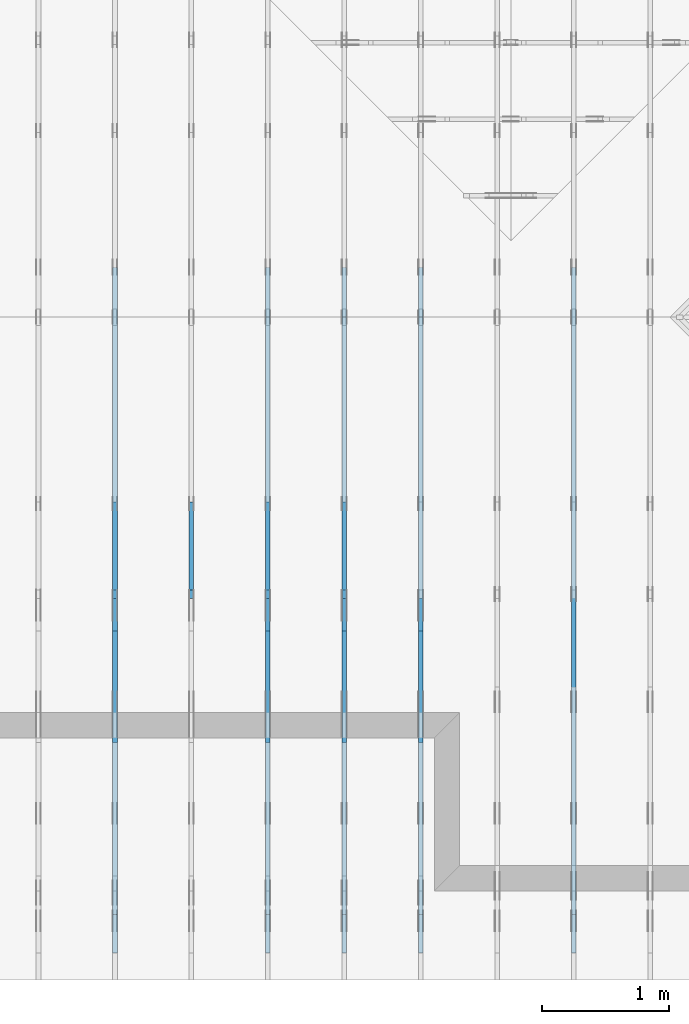
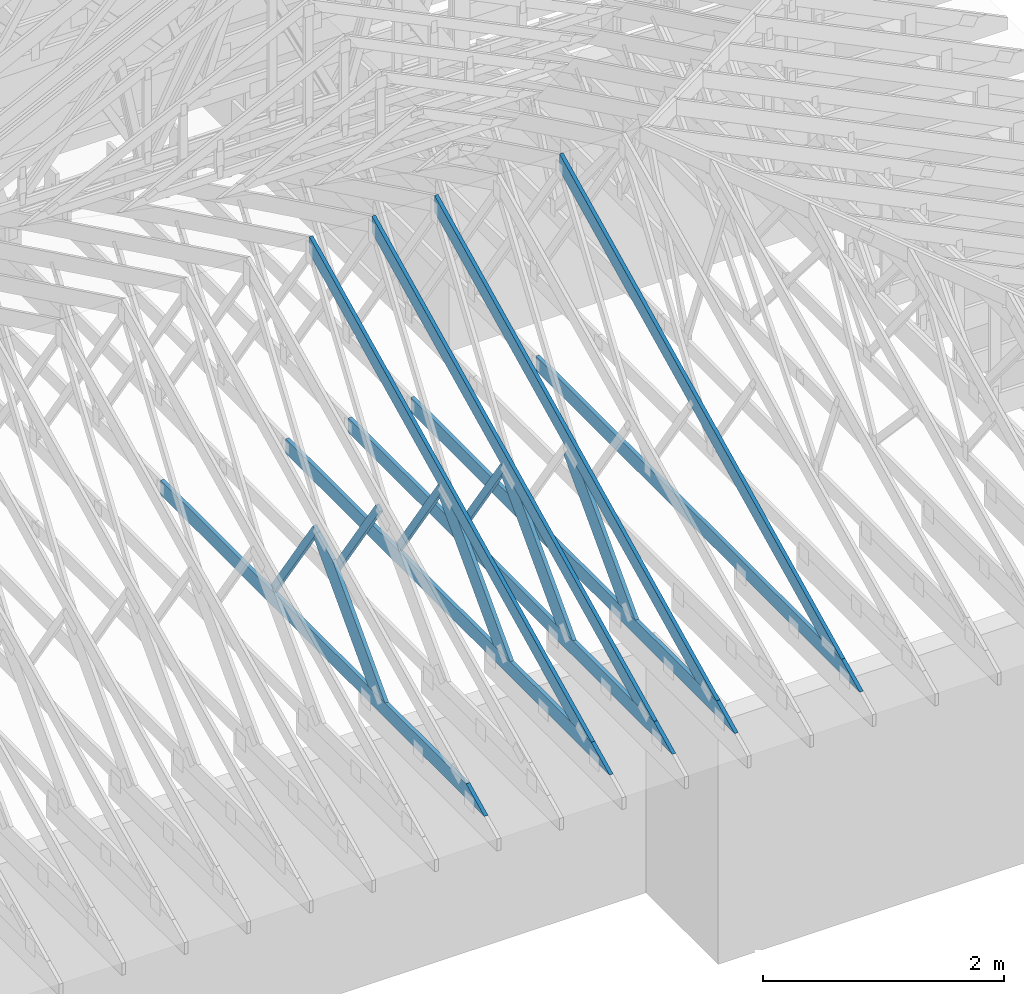
# One storey, part 14 of 159: 17 members, 6 elements without a shape of their own.
"""IFC2X3 building model written with IfcOpenShell, lengths in millimetres."""

from ifc_helpers import new_model, si_unit, frame, origin, origin_with_axes, origin_2d, place, context, project, spatial, faceted_brep, element, aggregate, save


model = new_model("IFC2X3")

# Units and contexts
model_context = context("Model", 3, precision=1e-05, world=origin())
plan_context = context("Plan", 2, precision=1e-05, world=origin_2d())
ifc_project = project(units=[si_unit("LENGTHUNIT", "METRE", prefix="MILLI"), si_unit("AREAUNIT", "SQUARE_METRE"), si_unit("VOLUMEUNIT", "CUBIC_METRE"), si_unit("SOLIDANGLEUNIT", "STERADIAN"), si_unit("PLANEANGLEUNIT", "RADIAN"), si_unit("MASSUNIT", "GRAM"), si_unit("TIMEUNIT", "SECOND"), si_unit("THERMODYNAMICTEMPERATUREUNIT", "DEGREE_CELSIUS"), si_unit("LUMINOUSINTENSITYUNIT", "LUMEN")], contexts=[model_context, plan_context])

# Site, building, storey
site_placement = place(None, origin_with_axes())
site = spatial("IfcSite", under=ifc_project, at=site_placement, CompositionType="ELEMENT")
building_placement = place(site_placement, origin_with_axes())
building = spatial("IfcBuilding", under=site, at=building_placement, Name="Plan 1", CompositionType="ELEMENT")
storey_placement = place(building_placement, origin_with_axes())
storey = spatial("IfcBuildingStorey", under=building, at=storey_placement, Name="Etasje 1", CompositionType="ELEMENT", Elevation=0.0)

# Assembly, members
assembly_1_placement = place(storey_placement, frame((15075.02226140475, -699.9989301294845, 1.1021457184401395e-15), z_axis=(-1.0, 1.836909530733566e-16, 6.123031769111886e-17), x_axis=(-1.836909530733566e-16, -1.0, 0.0)))
assembly_1 = element("IfcElementAssembly", 1, at=assembly_1_placement, inside=storey, Name="T7 (103)", AssemblyPlace="FACTORY", PredefinedType="TRUSS")
member_1_placement = place(assembly_1_placement, frame((-5264.878447895178, 2523.1876964355156, -36.0), z_axis=(0.0, 0.0, 1.0), x_axis=(0.8987940462991668, -0.4383711467890778, 0.0)))
member_1 = element("IfcMember", 2, at=member_1_placement, Name="T7-O3", context=model_context, shape_type="Brep", body=[
    faceted_brep([(5212.95535395332, 148.00000154094027, 36.0), (0.0, 148.00000154094027, 36.0), (72.18440200989608, 5.7974317996922764e-05, 36.0), (4909.510382240189, 5.7974317996922764e-05, 36.0), (0.0, 148.00000154094027, 0.0), (5212.95535395332, 148.00000154094027, 6.383818248643616e-13), (4909.510382240189, 5.7974317996922764e-05, 6.012217608248263e-13), (72.18440200989608, 5.7974317996922764e-05, 8.839747734818752e-15), (72.18447769922204, 9.2140264804641e-06, -7.888609052210118e-31), (72.18447769922206, 9.2140264804641e-06, 36.0), (5.4591825588090614e-05, 148.00000921330525, 36.0), (5.4591825588090614e-05, 148.00000921330525, -7.888609052210118e-31), (4909.510401129447, 9.21290418597988e-06, 1.6550270895783706e-28), (4909.510401129447, 9.212904188184172e-06, 36.0), (72.18447769922204, 9.21402643937418e-06, 36.0), (72.18447769922204, 9.214026437169889e-06, 2.433384460947949e-30), (5212.955369681814, 148.00000921223887, 1.0605704288840677e-29), (5212.955369681814, 148.00000921223887, 36.0), (4909.510401129447, 9.212906661559828e-06, 36.0), (4909.510401129447, 9.212906661559828e-06, -1.359749288005947e-29), (5.459182557387976e-05, 148.00000921330525, 0.0), (5.459182557387976e-05, 148.00000921330525, 36.0), (5212.955369681813, 148.00000921223887, 36.0), (5212.955369681813, 148.00000921223887, 7.888609052210118e-30)], [[[0, 1, 2, 3]], [[4, 5, 6, 7]], [[8, 9, 10, 11]], [[12, 13, 14, 15]], [[16, 17, 18, 19]], [[20, 21, 22, 23]]]),
])
member_2_placement = place(assembly_1_placement, frame((-211.18128967285153, 370.99999999999994, -36.0), z_axis=(0.0, 0.0, 1.0), x_axis=(-1.0, 1.2246063538223773e-16, 0.0)))
member_2 = element("IfcMember", 3, at=member_2_placement, Name="T7-U32", context=model_context, shape_type="Brep", body=[
    faceted_brep([(5379.999862670898, 148.00000000000063, 36.0), (0.0, 148.00000000000063, 36.0), (303.4449920654297, 0.0, 36.0), (5379.999862670898, 0.0, 36.0), (0.0, 148.00000000000063, 0.0), (5379.999862670898, 148.00000000000063, 6.588382015390299e-13), (5379.999862670898, 0.0, 6.588382015390299e-13), (303.4449920654297, 0.0, 3.7160066531890605e-14), (303.44497456401575, -1.8474111129762605e-13, 1.4199496293978212e-29), (303.44497456401575, -1.8474111129762605e-13, 36.0), (6.010755903673726e-06, 148.0, 36.0), (6.010755903673726e-06, 148.0, -1.5777218104420236e-30), (5380.000006010756, -1.0494167752128893e-12, 1.2690585325561372e-28), (5380.000006010756, -1.047212483776009e-12, 36.0), (303.44497456401587, -1.146952517202135e-13, 36.0), (303.44497456401587, -1.1689954315709379e-13, 7.157796165455513e-30), (5380.000006010756, 148.000000000001, 0.0), (5380.000006010756, 148.000000000001, 36.0), (5380.000006010756, 1.0231815394945443e-12, 36.0), (5380.000006010756, 1.0231815394945443e-12, 0.0), (6.010755896568298e-06, 147.99999999999997, 0.0), (6.010755896568298e-06, 147.99999999999997, 36.0), (5380.000006010756, 148.00000000000082, 36.0), (5380.000006010756, 148.00000000000082, -9.466330862652142e-30)], [[[0, 1, 2, 3]], [[4, 5, 6, 7]], [[8, 9, 10, 11]], [[12, 13, 14, 15]], [[16, 17, 18, 19]], [[20, 21, 22, 23]]]),
])
aggregate(assembly_1, [member_1, member_2])

assembly_2_placement = place(storey_placement, frame((13875.022261404752, -699.9989301294836, 1.1021457184401395e-15), z_axis=(-1.0, 1.836909530733566e-16, 6.123031769111886e-17), x_axis=(-1.836909530733566e-16, -1.0, 0.0)))
assembly_2 = element("IfcElementAssembly", 4, at=assembly_2_placement, inside=storey, Name="T6 (101)", AssemblyPlace="FACTORY", PredefinedType="TRUSS")
member_3_placement = place(assembly_2_placement, frame((-5264.878447895178, 2523.1876964355156, -36.0), z_axis=(0.0, 0.0, 1.0), x_axis=(0.8987940462991668, -0.4383711467890778, 0.0)))
member_3 = element("IfcMember", 5, at=member_3_placement, Name="T6-O3", context=model_context, shape_type="Brep", body=[
    faceted_brep([(5212.95535395332, 148.00000154094027, 36.0), (0.0, 148.00000154094027, 36.0), (72.18440200989608, 5.7974317996922764e-05, 36.0), (4909.510382240189, 5.7974317996922764e-05, 36.0), (0.0, 148.00000154094027, 0.0), (5212.95535395332, 148.00000154094027, 6.383818248643616e-13), (4909.510382240189, 5.7974317996922764e-05, 6.012217608248263e-13), (72.18440200989608, 5.7974317996922764e-05, 8.839747734818752e-15), (72.18447769922204, 9.2140264804641e-06, -7.888609052210118e-31), (72.18447769922206, 9.2140264804641e-06, 36.0), (5.4591825588090614e-05, 148.00000921330525, 36.0), (5.4591825588090614e-05, 148.00000921330525, -7.888609052210118e-31), (4909.510401129447, 9.21290418597988e-06, 1.6550270895783706e-28), (4909.510401129447, 9.212904188184172e-06, 36.0), (72.18447769922204, 9.21402643937418e-06, 36.0), (72.18447769922204, 9.214026437169889e-06, 2.433384460947949e-30), (5212.955369681814, 148.00000921223887, 1.0605704288840677e-29), (5212.955369681814, 148.00000921223887, 36.0), (4909.510401129447, 9.212906661559828e-06, 36.0), (4909.510401129447, 9.212906661559828e-06, -1.359749288005947e-29), (5.459182557387976e-05, 148.00000921330525, 0.0), (5.459182557387976e-05, 148.00000921330525, 36.0), (5212.955369681813, 148.00000921223887, 36.0), (5212.955369681813, 148.00000921223887, 7.888609052210118e-30)], [[[0, 1, 2, 3]], [[4, 5, 6, 7]], [[8, 9, 10, 11]], [[12, 13, 14, 15]], [[16, 17, 18, 19]], [[20, 21, 22, 23]]]),
])
member_4_placement = place(assembly_2_placement, frame((-211.18128967285153, 370.99999999999994, -36.0), z_axis=(0.0, 0.0, 1.0), x_axis=(-1.0, 1.2246063538223773e-16, 0.0)))
member_4 = element("IfcMember", 6, at=member_4_placement, Name="T6-U32", context=model_context, shape_type="Brep", body=[
    faceted_brep([(5379.999862670898, 148.00000000000063, 36.0), (0.0, 148.00000000000063, 36.0), (303.4449920654297, 0.0, 36.0), (5379.999862670898, 0.0, 36.0), (0.0, 148.00000000000063, 0.0), (5379.999862670898, 148.00000000000063, 6.588382015390299e-13), (5379.999862670898, 0.0, 6.588382015390299e-13), (303.4449920654297, 0.0, 3.7160066531890605e-14), (303.44497456401575, -1.8474111129762605e-13, 1.4199496293978212e-29), (303.44497456401575, -1.8474111129762605e-13, 36.0), (6.010755903673726e-06, 148.0, 36.0), (6.010755903673726e-06, 148.0, -1.5777218104420236e-30), (5380.000006010756, -1.0494167752128893e-12, 1.2690585325561372e-28), (5380.000006010756, -1.047212483776009e-12, 36.0), (303.44497456401587, -1.146952517202135e-13, 36.0), (303.44497456401587, -1.1689954315709379e-13, 7.157796165455513e-30), (5380.000006010756, 148.000000000001, 0.0), (5380.000006010756, 148.000000000001, 36.0), (5380.000006010756, 1.0231815394945443e-12, 36.0), (5380.000006010756, 1.0231815394945443e-12, 0.0), (6.010755896568298e-06, 147.99999999999997, 0.0), (6.010755896568298e-06, 147.99999999999997, 36.0), (5380.000006010756, 148.00000000000082, 36.0), (5380.000006010756, 148.00000000000082, -9.466330862652142e-30)], [[[0, 1, 2, 3]], [[4, 5, 6, 7]], [[8, 9, 10, 11]], [[12, 13, 14, 15]], [[16, 17, 18, 19]], [[20, 21, 22, 23]]]),
])
member_5_placement = place(assembly_2_placement, frame((-3064.6757649958863, 1346.8492734428223, -36.0), z_axis=(0.0, 0.0, 1.0), x_axis=(0.6894016878176602, -0.7243792603561765, 0.0)))
member_5 = element("IfcMember", 7, at=member_5_placement, Name="T6-D3", context=model_context, shape_type="Brep", body=[
    faceted_brep([(1535.5918255141082, 198.00009159272804, 36.0), (265.95807658513104, 198.00009159272804, 36.0), (0.0, 99.00008285369722, 36.0), (21.1644449327855, 0.0, 36.0), (1347.1524748391525, 0.0, 36.0), (265.95807658513104, 198.00009159272804, 3.256939504365299e-14), (1535.5918255141082, 198.00009159272804, 1.8804955064022803e-13), (1347.1524748391525, 0.0, 1.6497314802555664e-13), (21.1644449327855, 0.0, 2.5918113739812938e-15), (0.0, 99.00008285369722, 0.0), (4.264463813541397e-05, 99.00009494304574, 8.9528506660674e-31), (4.264463813541397e-05, 99.00009494304574, 36.0), (265.9581340926615, 198.000094942845, 36.0), (265.9581340926615, 198.000094942845, 5.714073875343044e-30), (21.164497648067943, 9.494284540778608e-05, -1.97215226305253e-31), (21.164497648067943, 9.494284540867426e-05, 36.0), (4.264463818515196e-05, 99.00009494304575, 36.0), (4.264463818159925e-05, 99.00009494304575, -2.5637979419682884e-30), (1347.1525101598781, 9.494284280359457e-05, 2.0233849336071296e-29), (1347.1525101598781, 9.494284280579886e-05, 36.0), (21.164497648067936, 9.494284540479874e-05, 36.0), (21.164497648067936, 9.494284540259445e-05, 3.1788526975049665e-31), (1535.5918287024588, 198.00009494284234, 5.048709793414476e-29), (1535.5918287024588, 198.00009494284234, 36.0), (1347.1525101598784, 9.494284279298881e-05, 36.0), (1347.1525101598784, 9.494284279298881e-05, 3.7865323450608567e-29), (265.95813409266157, 198.00009494284495, 0.0), (265.95813409266157, 198.00009494284495, 36.0), (1535.5918287024583, 198.00009494284262, 36.0), (1535.5918287024583, 198.00009494284262, -4.733165431326071e-30)], [[[0, 1, 2, 3, 4]], [[5, 6, 7, 8, 9]], [[10, 11, 12, 13]], [[14, 15, 16, 17]], [[18, 19, 20, 21]], [[22, 23, 24, 25]], [[26, 27, 28, 29]]]),
])
aggregate(assembly_2, [member_3, member_4, member_5])

assembly_3_placement = place(storey_placement, frame((13275.022261404752, -699.9989301294836, 1.1021457184401395e-15), z_axis=(-1.0, 1.836909530733566e-16, 6.123031769111886e-17), x_axis=(-1.836909530733566e-16, -1.0, 0.0)))
assembly_3 = element("IfcElementAssembly", 8, at=assembly_3_placement, inside=storey, Name="T6 (100)", AssemblyPlace="FACTORY", PredefinedType="TRUSS")
member_6_placement = place(assembly_3_placement, frame((-5264.878447895178, 2523.1876964355156, -36.0), z_axis=(0.0, 0.0, 1.0), x_axis=(0.8987940462991668, -0.4383711467890778, 0.0)))
member_6 = element("IfcMember", 9, at=member_6_placement, Name="T6-O3", context=model_context, shape_type="Brep", body=[
    faceted_brep([(5212.95535395332, 148.00000154094027, 36.0), (0.0, 148.00000154094027, 36.0), (72.18440200989608, 5.7974317996922764e-05, 36.0), (4909.510382240189, 5.7974317996922764e-05, 36.0), (0.0, 148.00000154094027, 0.0), (5212.95535395332, 148.00000154094027, 6.383818248643616e-13), (4909.510382240189, 5.7974317996922764e-05, 6.012217608248263e-13), (72.18440200989608, 5.7974317996922764e-05, 8.839747734818752e-15), (72.18447769922204, 9.2140264804641e-06, -7.888609052210118e-31), (72.18447769922206, 9.2140264804641e-06, 36.0), (5.4591825588090614e-05, 148.00000921330525, 36.0), (5.4591825588090614e-05, 148.00000921330525, -7.888609052210118e-31), (4909.510401129447, 9.21290418597988e-06, 1.6550270895783706e-28), (4909.510401129447, 9.212904188184172e-06, 36.0), (72.18447769922204, 9.21402643937418e-06, 36.0), (72.18447769922204, 9.214026437169889e-06, 2.433384460947949e-30), (5212.955369681814, 148.00000921223887, 1.0605704288840677e-29), (5212.955369681814, 148.00000921223887, 36.0), (4909.510401129447, 9.212906661559828e-06, 36.0), (4909.510401129447, 9.212906661559828e-06, -1.359749288005947e-29), (5.459182557387976e-05, 148.00000921330525, 0.0), (5.459182557387976e-05, 148.00000921330525, 36.0), (5212.955369681813, 148.00000921223887, 36.0), (5212.955369681813, 148.00000921223887, 7.888609052210118e-30)], [[[0, 1, 2, 3]], [[4, 5, 6, 7]], [[8, 9, 10, 11]], [[12, 13, 14, 15]], [[16, 17, 18, 19]], [[20, 21, 22, 23]]]),
])
member_7_placement = place(assembly_3_placement, frame((-211.18128967285153, 370.99999999999994, -36.0), z_axis=(0.0, 0.0, 1.0), x_axis=(-1.0, 1.2246063538223773e-16, 0.0)))
member_7 = element("IfcMember", 10, at=member_7_placement, Name="T6-U32", context=model_context, shape_type="Brep", body=[
    faceted_brep([(5379.999862670898, 148.00000000000063, 36.0), (0.0, 148.00000000000063, 36.0), (303.4449920654297, 0.0, 36.0), (5379.999862670898, 0.0, 36.0), (0.0, 148.00000000000063, 0.0), (5379.999862670898, 148.00000000000063, 6.588382015390299e-13), (5379.999862670898, 0.0, 6.588382015390299e-13), (303.4449920654297, 0.0, 3.7160066531890605e-14), (303.44497456401575, -1.8474111129762605e-13, 1.4199496293978212e-29), (303.44497456401575, -1.8474111129762605e-13, 36.0), (6.010755903673726e-06, 148.0, 36.0), (6.010755903673726e-06, 148.0, -1.5777218104420236e-30), (5380.000006010756, -1.0494167752128893e-12, 1.2690585325561372e-28), (5380.000006010756, -1.047212483776009e-12, 36.0), (303.44497456401587, -1.146952517202135e-13, 36.0), (303.44497456401587, -1.1689954315709379e-13, 7.157796165455513e-30), (5380.000006010756, 148.000000000001, 0.0), (5380.000006010756, 148.000000000001, 36.0), (5380.000006010756, 1.0231815394945443e-12, 36.0), (5380.000006010756, 1.0231815394945443e-12, 0.0), (6.010755896568298e-06, 147.99999999999997, 0.0), (6.010755896568298e-06, 147.99999999999997, 36.0), (5380.000006010756, 148.00000000000082, 36.0), (5380.000006010756, 148.00000000000082, -9.466330862652142e-30)], [[[0, 1, 2, 3]], [[4, 5, 6, 7]], [[8, 9, 10, 11]], [[12, 13, 14, 15]], [[16, 17, 18, 19]], [[20, 21, 22, 23]]]),
])
member_8_placement = place(assembly_3_placement, frame((-3053.2314180439453, 1456.2901995043017, -36.00000000000001), z_axis=(0.0, 0.0, 1.0), x_axis=(-0.5642475050080044, -0.8256056886263821, 0.0)))
member_8 = element("IfcMember", 11, at=member_8_placement, Name="T6-D42", context=model_context, shape_type="Brep", body=[
    faceted_brep([(1264.6473178393353, 73.00019836058664, 36.0), (2.90698949356738e-06, 73.00019836058664, 36.0), (10.714657584819633, 4.511090492087533e-05, 36.0), (1236.186095030735, 4.511090492087533e-05, 36.0), (2.90698949356738e-06, 73.00019836058664, 3.5599178043175084e-22), (1264.6473178393353, 73.00019836058664, 1.5486951407704775e-13), (1236.186095030735, 4.511090492087533e-05, 1.5138413464815112e-13), (10.714657584819633, 4.511090492087533e-05, 1.3121237757401251e-15), (10.714685884898016, 0.00010020237868935133, 1.010048471493429e-31), (10.714685884898017, 0.00010020237868957338, 36.0), (3.375077994860476e-14, 73.00010020237825, 36.0), (3.197442310920451e-14, 73.00010020237825, -2.1820420316813824e-30), (1236.1860298820347, 0.00010020237954454694, 5.902699555591949e-29), (1236.1860298820347, 0.00010020237954675123, 36.0), (10.714685884898017, 0.00010020237868342204, 36.0), (10.714685884898017, 0.00010020237868121774, 5.116180235117775e-31), (1264.6473849240515, 73.00010020238051, 2.686871379716991e-29), (1264.6473849240515, 73.00010020238051, 36.0), (1236.1860298820352, 0.00010020238050856278, 36.0), (1236.1860298820352, 0.00010020238050856278, 2.662727280413415e-29), (0.0, 73.00010020237823, 0.0), (0.0, 73.00010020237823, 36.0), (1264.647384924051, 73.0001002023804, 36.0), (1264.647384924051, 73.00010020238041, -7.099748146989106e-30)], [[[0, 1, 2, 3]], [[4, 5, 6, 7]], [[8, 9, 10, 11]], [[12, 13, 14, 15]], [[16, 17, 18, 19]], [[20, 21, 22, 23]]]),
])
member_9_placement = place(assembly_3_placement, frame((-3064.6757649958863, 1346.8492734428223, -36.0), z_axis=(0.0, 0.0, 1.0), x_axis=(0.6894016878176602, -0.7243792603561765, 0.0)))
member_9 = element("IfcMember", 12, at=member_9_placement, Name="T6-D3", context=model_context, shape_type="Brep", body=[
    faceted_brep([(1535.5918255141082, 198.00009159272804, 36.0), (265.95807658513104, 198.00009159272804, 36.0), (0.0, 99.00008285369722, 36.0), (21.1644449327855, 0.0, 36.0), (1347.1524748391525, 0.0, 36.0), (265.95807658513104, 198.00009159272804, 3.256939504365299e-14), (1535.5918255141082, 198.00009159272804, 1.8804955064022803e-13), (1347.1524748391525, 0.0, 1.6497314802555664e-13), (21.1644449327855, 0.0, 2.5918113739812938e-15), (0.0, 99.00008285369722, 0.0), (4.264463813541397e-05, 99.00009494304574, 8.9528506660674e-31), (4.264463813541397e-05, 99.00009494304574, 36.0), (265.9581340926615, 198.000094942845, 36.0), (265.9581340926615, 198.000094942845, 5.714073875343044e-30), (21.164497648067943, 9.494284540778608e-05, -1.97215226305253e-31), (21.164497648067943, 9.494284540867426e-05, 36.0), (4.264463818515196e-05, 99.00009494304575, 36.0), (4.264463818159925e-05, 99.00009494304575, -2.5637979419682884e-30), (1347.1525101598781, 9.494284280359457e-05, 2.0233849336071296e-29), (1347.1525101598781, 9.494284280579886e-05, 36.0), (21.164497648067936, 9.494284540479874e-05, 36.0), (21.164497648067936, 9.494284540259445e-05, 3.1788526975049665e-31), (1535.5918287024588, 198.00009494284234, 5.048709793414476e-29), (1535.5918287024588, 198.00009494284234, 36.0), (1347.1525101598784, 9.494284279298881e-05, 36.0), (1347.1525101598784, 9.494284279298881e-05, 3.7865323450608567e-29), (265.95813409266157, 198.00009494284495, 0.0), (265.95813409266157, 198.00009494284495, 36.0), (1535.5918287024583, 198.00009494284262, 36.0), (1535.5918287024583, 198.00009494284262, -4.733165431326071e-30)], [[[0, 1, 2, 3, 4]], [[5, 6, 7, 8, 9]], [[10, 11, 12, 13]], [[14, 15, 16, 17]], [[18, 19, 20, 21]], [[22, 23, 24, 25]], [[26, 27, 28, 29]]]),
])
aggregate(assembly_3, [member_6, member_7, member_8, member_9])

assembly_4_placement = place(storey_placement, frame((12675.022261404752, -699.9989301294854, 4.558494966049043e-13), z_axis=(-1.0, 1.836909530733566e-16, 6.123031769111886e-17), x_axis=(-1.836909530733566e-16, -1.0, 0.0)))
assembly_4 = element("IfcElementAssembly", 13, at=assembly_4_placement, inside=storey, Name="T6 (99)", AssemblyPlace="FACTORY", PredefinedType="TRUSS")
member_10_placement = place(assembly_4_placement, frame((-5264.878447895178, 2523.1876964355156, -36.0), z_axis=(0.0, 0.0, 1.0), x_axis=(0.8987940462991668, -0.4383711467890778, 0.0)))
member_10 = element("IfcMember", 14, at=member_10_placement, Name="T6-O3", context=model_context, shape_type="Brep", body=[
    faceted_brep([(5212.95535395332, 148.00000154094027, 36.0), (0.0, 148.00000154094027, 36.0), (72.18440200989608, 5.7974317996922764e-05, 36.0), (4909.510382240189, 5.7974317996922764e-05, 36.0), (0.0, 148.00000154094027, 0.0), (5212.95535395332, 148.00000154094027, 6.383818248643616e-13), (4909.510382240189, 5.7974317996922764e-05, 6.012217608248263e-13), (72.18440200989608, 5.7974317996922764e-05, 8.839747734818752e-15), (72.18447769922204, 9.2140264804641e-06, -7.888609052210118e-31), (72.18447769922206, 9.2140264804641e-06, 36.0), (5.4591825588090614e-05, 148.00000921330525, 36.0), (5.4591825588090614e-05, 148.00000921330525, -7.888609052210118e-31), (4909.510401129447, 9.21290418597988e-06, 1.6550270895783706e-28), (4909.510401129447, 9.212904188184172e-06, 36.0), (72.18447769922204, 9.21402643937418e-06, 36.0), (72.18447769922204, 9.214026437169889e-06, 2.433384460947949e-30), (5212.955369681814, 148.00000921223887, 1.0605704288840677e-29), (5212.955369681814, 148.00000921223887, 36.0), (4909.510401129447, 9.212906661559828e-06, 36.0), (4909.510401129447, 9.212906661559828e-06, -1.359749288005947e-29), (5.459182557387976e-05, 148.00000921330525, 0.0), (5.459182557387976e-05, 148.00000921330525, 36.0), (5212.955369681813, 148.00000921223887, 36.0), (5212.955369681813, 148.00000921223887, 7.888609052210118e-30)], [[[0, 1, 2, 3]], [[4, 5, 6, 7]], [[8, 9, 10, 11]], [[12, 13, 14, 15]], [[16, 17, 18, 19]], [[20, 21, 22, 23]]]),
])
member_11_placement = place(assembly_4_placement, frame((-211.18128967285153, 370.99999999999994, -36.0), z_axis=(0.0, 0.0, 1.0), x_axis=(-1.0, 1.2246063538223773e-16, 0.0)))
member_11 = element("IfcMember", 15, at=member_11_placement, Name="T6-U32", context=model_context, shape_type="Brep", body=[
    faceted_brep([(5379.999862670898, 148.00000000000063, 36.0), (0.0, 148.00000000000063, 36.0), (303.4449920654297, 0.0, 36.0), (5379.999862670898, 0.0, 36.0), (0.0, 148.00000000000063, 0.0), (5379.999862670898, 148.00000000000063, 6.588382015390299e-13), (5379.999862670898, 0.0, 6.588382015390299e-13), (303.4449920654297, 0.0, 3.7160066531890605e-14), (303.44497456401575, -1.8474111129762605e-13, 1.4199496293978212e-29), (303.44497456401575, -1.8474111129762605e-13, 36.0), (6.010755903673726e-06, 148.0, 36.0), (6.010755903673726e-06, 148.0, -1.5777218104420236e-30), (5380.000006010756, -1.0494167752128893e-12, 1.2690585325561372e-28), (5380.000006010756, -1.047212483776009e-12, 36.0), (303.44497456401587, -1.146952517202135e-13, 36.0), (303.44497456401587, -1.1689954315709379e-13, 7.157796165455513e-30), (5380.000006010756, 148.000000000001, 0.0), (5380.000006010756, 148.000000000001, 36.0), (5380.000006010756, 1.0231815394945443e-12, 36.0), (5380.000006010756, 1.0231815394945443e-12, 0.0), (6.010755896568298e-06, 147.99999999999997, 0.0), (6.010755896568298e-06, 147.99999999999997, 36.0), (5380.000006010756, 148.00000000000082, 36.0), (5380.000006010756, 148.00000000000082, -9.466330862652142e-30)], [[[0, 1, 2, 3]], [[4, 5, 6, 7]], [[8, 9, 10, 11]], [[12, 13, 14, 15]], [[16, 17, 18, 19]], [[20, 21, 22, 23]]]),
])
member_12_placement = place(assembly_4_placement, frame((-3053.2314180439453, 1456.2901995043017, -36.00000000000001), z_axis=(0.0, 0.0, 1.0), x_axis=(-0.5642475050080044, -0.8256056886263821, 0.0)))
member_12 = element("IfcMember", 16, at=member_12_placement, Name="T6-D42", context=model_context, shape_type="Brep", body=[
    faceted_brep([(1264.6473178393353, 73.00019836058664, 36.0), (2.90698949356738e-06, 73.00019836058664, 36.0), (10.714657584819633, 4.511090492087533e-05, 36.0), (1236.186095030735, 4.511090492087533e-05, 36.0), (2.90698949356738e-06, 73.00019836058664, 3.5599178043175084e-22), (1264.6473178393353, 73.00019836058664, 1.5486951407704775e-13), (1236.186095030735, 4.511090492087533e-05, 1.5138413464815112e-13), (10.714657584819633, 4.511090492087533e-05, 1.3121237757401251e-15), (10.714685884898016, 0.00010020237868935133, 1.010048471493429e-31), (10.714685884898017, 0.00010020237868957338, 36.0), (3.375077994860476e-14, 73.00010020237825, 36.0), (3.197442310920451e-14, 73.00010020237825, -2.1820420316813824e-30), (1236.1860298820347, 0.00010020237954454694, 5.902699555591949e-29), (1236.1860298820347, 0.00010020237954675123, 36.0), (10.714685884898017, 0.00010020237868342204, 36.0), (10.714685884898017, 0.00010020237868121774, 5.116180235117775e-31), (1264.6473849240515, 73.00010020238051, 2.686871379716991e-29), (1264.6473849240515, 73.00010020238051, 36.0), (1236.1860298820352, 0.00010020238050856278, 36.0), (1236.1860298820352, 0.00010020238050856278, 2.662727280413415e-29), (0.0, 73.00010020237823, 0.0), (0.0, 73.00010020237823, 36.0), (1264.647384924051, 73.0001002023804, 36.0), (1264.647384924051, 73.00010020238041, -7.099748146989106e-30)], [[[0, 1, 2, 3]], [[4, 5, 6, 7]], [[8, 9, 10, 11]], [[12, 13, 14, 15]], [[16, 17, 18, 19]], [[20, 21, 22, 23]]]),
])
member_13_placement = place(assembly_4_placement, frame((-3064.6757649958863, 1346.8492734428223, -36.0), z_axis=(0.0, 0.0, 1.0), x_axis=(0.6894016878176602, -0.7243792603561765, 0.0)))
member_13 = element("IfcMember", 17, at=member_13_placement, Name="T6-D3", context=model_context, shape_type="Brep", body=[
    faceted_brep([(1535.5918255141082, 198.00009159272804, 36.0), (265.95807658513104, 198.00009159272804, 36.0), (0.0, 99.00008285369722, 36.0), (21.1644449327855, 0.0, 36.0), (1347.1524748391525, 0.0, 36.0), (265.95807658513104, 198.00009159272804, 3.256939504365299e-14), (1535.5918255141082, 198.00009159272804, 1.8804955064022803e-13), (1347.1524748391525, 0.0, 1.6497314802555664e-13), (21.1644449327855, 0.0, 2.5918113739812938e-15), (0.0, 99.00008285369722, 0.0), (4.264463813541397e-05, 99.00009494304574, 8.9528506660674e-31), (4.264463813541397e-05, 99.00009494304574, 36.0), (265.9581340926615, 198.000094942845, 36.0), (265.9581340926615, 198.000094942845, 5.714073875343044e-30), (21.164497648067943, 9.494284540778608e-05, -1.97215226305253e-31), (21.164497648067943, 9.494284540867426e-05, 36.0), (4.264463818515196e-05, 99.00009494304575, 36.0), (4.264463818159925e-05, 99.00009494304575, -2.5637979419682884e-30), (1347.1525101598781, 9.494284280359457e-05, 2.0233849336071296e-29), (1347.1525101598781, 9.494284280579886e-05, 36.0), (21.164497648067936, 9.494284540479874e-05, 36.0), (21.164497648067936, 9.494284540259445e-05, 3.1788526975049665e-31), (1535.5918287024588, 198.00009494284234, 5.048709793414476e-29), (1535.5918287024588, 198.00009494284234, 36.0), (1347.1525101598784, 9.494284279298881e-05, 36.0), (1347.1525101598784, 9.494284279298881e-05, 3.7865323450608567e-29), (265.95813409266157, 198.00009494284495, 0.0), (265.95813409266157, 198.00009494284495, 36.0), (1535.5918287024583, 198.00009494284262, 36.0), (1535.5918287024583, 198.00009494284262, -4.733165431326071e-30)], [[[0, 1, 2, 3, 4]], [[5, 6, 7, 8, 9]], [[10, 11, 12, 13]], [[14, 15, 16, 17]], [[18, 19, 20, 21]], [[22, 23, 24, 25]], [[26, 27, 28, 29]]]),
])
aggregate(assembly_4, [member_10, member_11, member_12, member_13])

# Assembly, member
assembly_5_placement = place(storey_placement, frame((12075.022261404752, -699.9989301294854, 4.558494966049043e-13), z_axis=(-1.0, 1.836909530733566e-16, 6.123031769111886e-17), x_axis=(-1.836909530733566e-16, -1.0, 0.0)))
assembly_5 = element("IfcElementAssembly", 18, at=assembly_5_placement, inside=storey, Name="T5 (98)", AssemblyPlace="FACTORY", PredefinedType="TRUSS")
member_14_placement = place(assembly_5_placement, frame((-3053.2314180439453, 1456.2901995043017, -36.00000000000001), z_axis=(0.0, 0.0, 1.0), x_axis=(-0.5642475050080044, -0.8256056886263821, 0.0)))
member_14 = element("IfcMember", 19, at=member_14_placement, Name="T5-D42", context=model_context, shape_type="Brep", body=[
    faceted_brep([(1264.6473178393353, 73.00019836058664, 36.0), (2.90698949356738e-06, 73.00019836058664, 36.0), (10.714657584819633, 4.511090492087533e-05, 36.0), (1236.186095030735, 4.511090492087533e-05, 36.0), (2.90698949356738e-06, 73.00019836058664, 3.5599178043175084e-22), (1264.6473178393353, 73.00019836058664, 1.5486951407704775e-13), (1236.186095030735, 4.511090492087533e-05, 1.5138413464815112e-13), (10.714657584819633, 4.511090492087533e-05, 1.3121237757401251e-15), (10.714685884898016, 0.00010020237868935133, 1.010048471493429e-31), (10.714685884898017, 0.00010020237868957338, 36.0), (3.375077994860476e-14, 73.00010020237825, 36.0), (3.197442310920451e-14, 73.00010020237825, -2.1820420316813824e-30), (1236.1860298820347, 0.00010020237954454694, 5.902699555591949e-29), (1236.1860298820347, 0.00010020237954675123, 36.0), (10.714685884898017, 0.00010020237868342204, 36.0), (10.714685884898017, 0.00010020237868121774, 5.116180235117775e-31), (1264.6473849240515, 73.00010020238051, 2.686871379716991e-29), (1264.6473849240515, 73.00010020238051, 36.0), (1236.1860298820352, 0.00010020238050856278, 36.0), (1236.1860298820352, 0.00010020238050856278, 2.662727280413415e-29), (0.0, 73.00010020237823, 0.0), (0.0, 73.00010020237823, 36.0), (1264.647384924051, 73.0001002023804, 36.0), (1264.647384924051, 73.00010020238041, -7.099748146989106e-30)], [[[0, 1, 2, 3]], [[4, 5, 6, 7]], [[8, 9, 10, 11]], [[12, 13, 14, 15]], [[16, 17, 18, 19]], [[20, 21, 22, 23]]]),
])
aggregate(assembly_5, [member_14])

# Assembly, members
assembly_6_placement = place(storey_placement, frame((11475.022261404752, -699.9989301294845, 1.1021457184401395e-15), z_axis=(-1.0, 1.836909530733566e-16, 6.123031769111886e-17), x_axis=(-1.836909530733566e-16, -1.0, 0.0)))
assembly_6 = element("IfcElementAssembly", 20, at=assembly_6_placement, inside=storey, Name="T5 (97)", AssemblyPlace="FACTORY", PredefinedType="TRUSS")
member_15_placement = place(assembly_6_placement, frame((-211.18128967285153, 370.99999999999994, -36.0), z_axis=(0.0, 0.0, 1.0), x_axis=(-1.0, 1.2246063538223773e-16, 0.0)))
member_15 = element("IfcMember", 21, at=member_15_placement, Name="T5-U32", context=model_context, shape_type="Brep", body=[
    faceted_brep([(5379.999862670898, 148.00000000000063, 36.0), (0.0, 148.00000000000063, 36.0), (303.4449920654297, 0.0, 36.0), (5379.999862670898, 0.0, 36.0), (0.0, 148.00000000000063, 0.0), (5379.999862670898, 148.00000000000063, 6.588382015390299e-13), (5379.999862670898, 0.0, 6.588382015390299e-13), (303.4449920654297, 0.0, 3.7160066531890605e-14), (303.44497456401575, -1.8474111129762605e-13, 1.4199496293978212e-29), (303.44497456401575, -1.8474111129762605e-13, 36.0), (6.010755903673726e-06, 148.0, 36.0), (6.010755903673726e-06, 148.0, -1.5777218104420236e-30), (5380.000006010756, -1.0494167752128893e-12, 1.2690585325561372e-28), (5380.000006010756, -1.047212483776009e-12, 36.0), (303.44497456401587, -1.146952517202135e-13, 36.0), (303.44497456401587, -1.1689954315709379e-13, 7.157796165455513e-30), (5380.000006010756, 148.000000000001, 0.0), (5380.000006010756, 148.000000000001, 36.0), (5380.000006010756, 1.0231815394945443e-12, 36.0), (5380.000006010756, 1.0231815394945443e-12, 0.0), (6.010755896568298e-06, 147.99999999999997, 0.0), (6.010755896568298e-06, 147.99999999999997, 36.0), (5380.000006010756, 148.00000000000082, 36.0), (5380.000006010756, 148.00000000000082, -9.466330862652142e-30)], [[[0, 1, 2, 3]], [[4, 5, 6, 7]], [[8, 9, 10, 11]], [[12, 13, 14, 15]], [[16, 17, 18, 19]], [[20, 21, 22, 23]]]),
])
member_16_placement = place(assembly_6_placement, frame((-3053.2314180439453, 1456.2901995043017, -36.00000000000001), z_axis=(0.0, 0.0, 1.0), x_axis=(-0.5642475050080044, -0.8256056886263821, 0.0)))
member_16 = element("IfcMember", 22, at=member_16_placement, Name="T5-D42", context=model_context, shape_type="Brep", body=[
    faceted_brep([(1264.6473178393353, 73.00019836058664, 36.0), (2.90698949356738e-06, 73.00019836058664, 36.0), (10.714657584819633, 4.511090492087533e-05, 36.0), (1236.186095030735, 4.511090492087533e-05, 36.0), (2.90698949356738e-06, 73.00019836058664, 3.5599178043175084e-22), (1264.6473178393353, 73.00019836058664, 1.5486951407704775e-13), (1236.186095030735, 4.511090492087533e-05, 1.5138413464815112e-13), (10.714657584819633, 4.511090492087533e-05, 1.3121237757401251e-15), (10.714685884898016, 0.00010020237868935133, 1.010048471493429e-31), (10.714685884898017, 0.00010020237868957338, 36.0), (3.375077994860476e-14, 73.00010020237825, 36.0), (3.197442310920451e-14, 73.00010020237825, -2.1820420316813824e-30), (1236.1860298820347, 0.00010020237954454694, 5.902699555591949e-29), (1236.1860298820347, 0.00010020237954675123, 36.0), (10.714685884898017, 0.00010020237868342204, 36.0), (10.714685884898017, 0.00010020237868121774, 5.116180235117775e-31), (1264.6473849240515, 73.00010020238051, 2.686871379716991e-29), (1264.6473849240515, 73.00010020238051, 36.0), (1236.1860298820352, 0.00010020238050856278, 36.0), (1236.1860298820352, 0.00010020238050856278, 2.662727280413415e-29), (0.0, 73.00010020237823, 0.0), (0.0, 73.00010020237823, 36.0), (1264.647384924051, 73.0001002023804, 36.0), (1264.647384924051, 73.00010020238041, -7.099748146989106e-30)], [[[0, 1, 2, 3]], [[4, 5, 6, 7]], [[8, 9, 10, 11]], [[12, 13, 14, 15]], [[16, 17, 18, 19]], [[20, 21, 22, 23]]]),
])
member_17_placement = place(assembly_6_placement, frame((-3064.6757649958863, 1346.8492734428223, -36.0), z_axis=(0.0, 0.0, 1.0), x_axis=(0.6894016878176602, -0.7243792603561765, 0.0)))
member_17 = element("IfcMember", 23, at=member_17_placement, Name="T5-D3", context=model_context, shape_type="Brep", body=[
    faceted_brep([(1535.5918255141082, 198.00009159272804, 36.0), (265.95807658513104, 198.00009159272804, 36.0), (0.0, 99.00008285369722, 36.0), (21.1644449327855, 0.0, 36.0), (1347.1524748391525, 0.0, 36.0), (265.95807658513104, 198.00009159272804, 3.256939504365299e-14), (1535.5918255141082, 198.00009159272804, 1.8804955064022803e-13), (1347.1524748391525, 0.0, 1.6497314802555664e-13), (21.1644449327855, 0.0, 2.5918113739812938e-15), (0.0, 99.00008285369722, 0.0), (4.264463813541397e-05, 99.00009494304574, 8.9528506660674e-31), (4.264463813541397e-05, 99.00009494304574, 36.0), (265.9581340926615, 198.000094942845, 36.0), (265.9581340926615, 198.000094942845, 5.714073875343044e-30), (21.164497648067943, 9.494284540778608e-05, -1.97215226305253e-31), (21.164497648067943, 9.494284540867426e-05, 36.0), (4.264463818515196e-05, 99.00009494304575, 36.0), (4.264463818159925e-05, 99.00009494304575, -2.5637979419682884e-30), (1347.1525101598781, 9.494284280359457e-05, 2.0233849336071296e-29), (1347.1525101598781, 9.494284280579886e-05, 36.0), (21.164497648067936, 9.494284540479874e-05, 36.0), (21.164497648067936, 9.494284540259445e-05, 3.1788526975049665e-31), (1535.5918287024588, 198.00009494284234, 5.048709793414476e-29), (1535.5918287024588, 198.00009494284234, 36.0), (1347.1525101598784, 9.494284279298881e-05, 36.0), (1347.1525101598784, 9.494284279298881e-05, 3.7865323450608567e-29), (265.95813409266157, 198.00009494284495, 0.0), (265.95813409266157, 198.00009494284495, 36.0), (1535.5918287024583, 198.00009494284262, 36.0), (1535.5918287024583, 198.00009494284262, -4.733165431326071e-30)], [[[0, 1, 2, 3, 4]], [[5, 6, 7, 8, 9]], [[10, 11, 12, 13]], [[14, 15, 16, 17]], [[18, 19, 20, 21]], [[22, 23, 24, 25]], [[26, 27, 28, 29]]]),
])
aggregate(assembly_6, [member_15, member_16, member_17])

save(model, "model.ifc")
